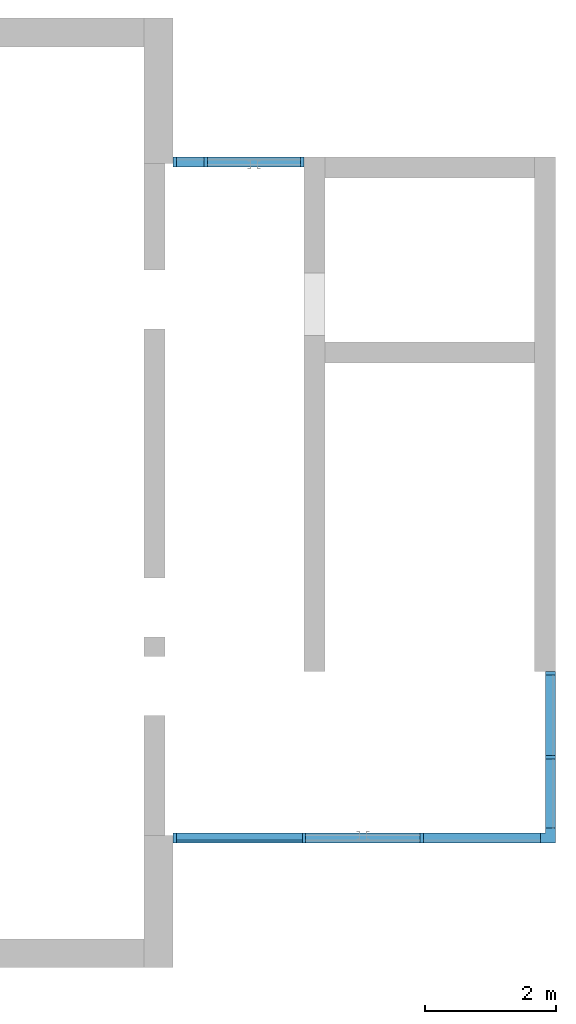
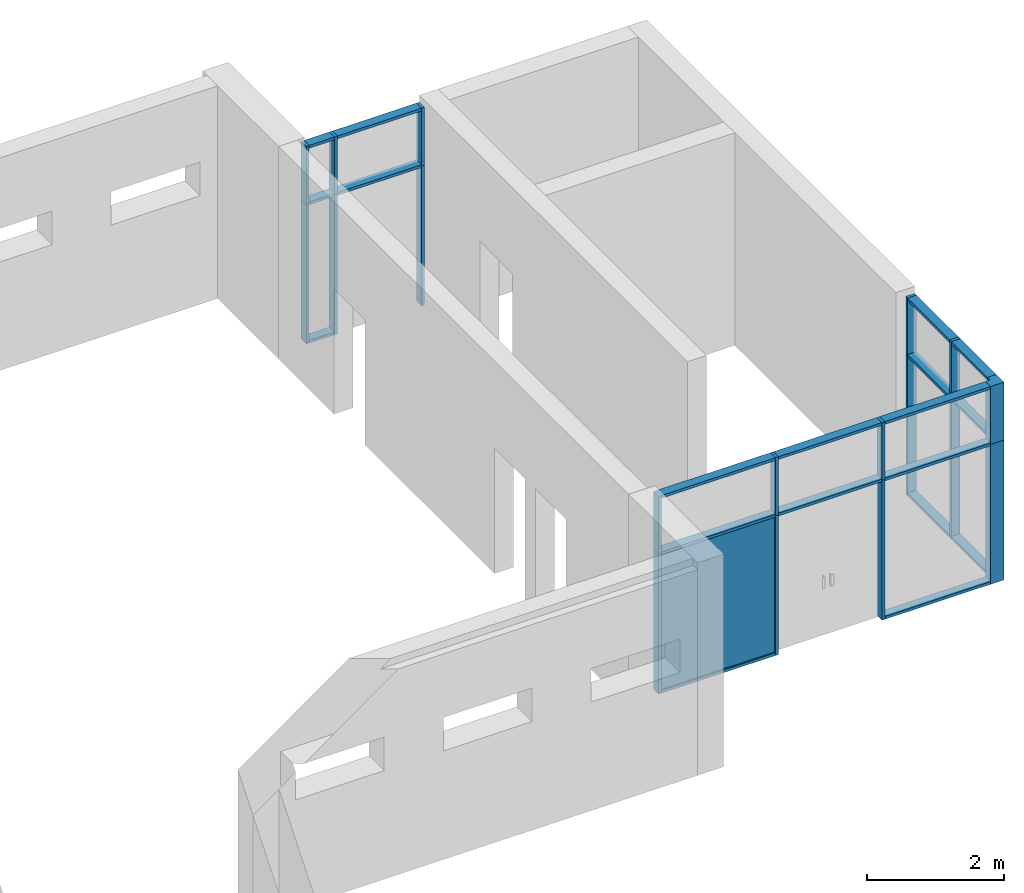
# One storey, part 1 of 4: 37 members, 1 plate, 3 elements without a shape of their own.
"""IFC2X3 building model written with IfcOpenShell, lengths in millimetres."""

from ifc_helpers import new_model, entity, si_unit, converted_unit, derived_unit, direction, frame, frame_2d, origin, origin_2d_with_axis, place, context, subcontext, project, spatial, polyline, rectangle, outline, extrude, source, transform, mapped, material, layer, layer_set, layer_usage, type_object, type_shapes, element, aggregate, save


model = new_model("IFC2X3")

# Units and contexts
model_context = context("Model", 3, precision=0.01, world=origin(), true_north=direction((6.12303176911189e-17, 1.0)))
body_context = subcontext(model_context, "Body", "Model", "MODEL_VIEW")
ifc_project = project(units=[si_unit("LENGTHUNIT", "METRE", prefix="MILLI"), si_unit("AREAUNIT", "SQUARE_METRE"), si_unit("VOLUMEUNIT", "CUBIC_METRE"), converted_unit("PLANEANGLEUNIT", "DEGREE", entity("IfcRatioMeasure", 0.0174532925199433), si_unit("PLANEANGLEUNIT", "RADIAN"), dimensions=[0, 0, 0, 0, 0, 0, 0]), si_unit("MASSUNIT", "GRAM", prefix="KILO"), derived_unit("MASSDENSITYUNIT", [(si_unit("MASSUNIT", "GRAM", prefix="KILO"), 1), (si_unit("LENGTHUNIT", "METRE"), -3)]), si_unit("TIMEUNIT", "SECOND"), si_unit("FREQUENCYUNIT", "HERTZ"), si_unit("THERMODYNAMICTEMPERATUREUNIT", "DEGREE_CELSIUS"), derived_unit("THERMALTRANSMITTANCEUNIT", [(si_unit("MASSUNIT", "GRAM", prefix="KILO"), 1), (si_unit("THERMODYNAMICTEMPERATUREUNIT", "KELVIN"), -1), (si_unit("TIMEUNIT", "SECOND"), -3)]), derived_unit("VOLUMETRICFLOWRATEUNIT", [(si_unit("LENGTHUNIT", "METRE"), 3), (si_unit("TIMEUNIT", "SECOND"), -1)]), si_unit("ELECTRICCURRENTUNIT", "AMPERE"), si_unit("ELECTRICVOLTAGEUNIT", "VOLT"), si_unit("POWERUNIT", "WATT"), si_unit("FORCEUNIT", "NEWTON", prefix="KILO"), si_unit("ILLUMINANCEUNIT", "LUX"), si_unit("LUMINOUSFLUXUNIT", "LUMEN"), si_unit("LUMINOUSINTENSITYUNIT", "CANDELA"), derived_unit("USERDEFINED", [(si_unit("MASSUNIT", "GRAM", prefix="KILO"), -1), (si_unit("LENGTHUNIT", "METRE"), -2), (si_unit("TIMEUNIT", "SECOND"), 3), (si_unit("LUMINOUSFLUXUNIT", "LUMEN"), 1)]), derived_unit("LINEARVELOCITYUNIT", [(si_unit("LENGTHUNIT", "METRE"), 1), (si_unit("TIMEUNIT", "SECOND"), -1)]), si_unit("PRESSUREUNIT", "PASCAL"), derived_unit("USERDEFINED", [(si_unit("LENGTHUNIT", "METRE"), -2), (si_unit("MASSUNIT", "GRAM", prefix="KILO"), 1), (si_unit("TIMEUNIT", "SECOND"), -2)])], contexts=[model_context])

# Site, building, storey
site_placement = place(None, origin())
site = spatial("IfcSite", under=ifc_project, at=site_placement, CompositionType="ELEMENT")
building_placement = place(site_placement, origin())
building = spatial("IfcBuilding", under=site, at=building_placement, CompositionType="ELEMENT")
storey_placement = place(building_placement, origin())
storey = spatial("IfcBuildingStorey", under=building, at=storey_placement, Name="00 Ground level", CompositionType="ELEMENT", Elevation=0.0)

# Curtain wall, member
curtain_wall_type = type_object("IfcCurtainWallType", Name="Curtain Wall", PredefinedType="NOTDEFINED")
curtain_wall_1_placement = place(storey_placement, origin())
curtain_wall_1 = element("IfcCurtainWall", 1, at=curtain_wall_1_placement, inside=storey, type_object=curtain_wall_type, Name="Curtain Wall", ObjectType="Curtain Wall")
ifc_material_1 = material(Name="Aluminium")
member_type_1 = type_object("IfcMemberType", Name="50 x 150mm", PredefinedType="MEMBER")
shared_shape_1 = source(origin(), body_context, "Body", "SweptSolid", [
    extrude(rectangle(XDim=150.0, YDim=50.0, at=origin_2d_with_axis()), frame((-25.0, 0.0, -1035.0), z_axis=(0.0, 0.0, 1.0), x_axis=(0.0, -1.0, 0.0)), (0.0, 0.0, 1.0), 1035.0),
])
type_shapes(member_type_1, [shared_shape_1])
member_1_placement = place(storey_placement, frame((28943.4900708518, -74100.8241905963, 3535.0), z_axis=(0.0, 0.0, 1.0), x_axis=(-1.0, 0.0, 0.0)))
member_1 = element("IfcMember", 2, at=member_1_placement, type_object=member_type_1, material=ifc_material_1, Name="Rectangular Mullion:50 x 150mm", ObjectType="Rectangular Mullion:50 x 150mm", context=body_context, shape_type="MappedRepresentation", body=[
    mapped(shared_shape_1, transform((0.0, 0.0, 0.0), scale=1.0)),
])

curtain_wall_2_placement = place(storey_placement, origin())
curtain_wall_2 = element("IfcCurtainWall", 3, at=curtain_wall_2_placement, inside=storey, type_object=curtain_wall_type, Name="Curtain Wall", ObjectType="Curtain Wall")
member_2_placement = place(storey_placement, frame((30943.4900708518, -63780.8241905964, 3535.0)))
member_2 = element("IfcMember", 4, at=member_2_placement, type_object=member_type_1, material=ifc_material_1, Name="Rectangular Mullion:50 x 150mm", ObjectType="Rectangular Mullion:50 x 150mm", context=body_context, shape_type="MappedRepresentation", body=[
    mapped(shared_shape_1, transform((0.0, 0.0, 0.0), scale=1.0)),
])

# Member
member_type_2 = type_object("IfcMemberType", Name="50 x 150mm", PredefinedType="MEMBER")
shared_shape_2 = source(origin(), body_context, "Body", "SweptSolid", [
    extrude(rectangle(XDim=150.0, YDim=50.0, at=origin_2d_with_axis()), frame((-25.0, 0.0, -1790.0), z_axis=(0.0, 0.0, 1.0), x_axis=(0.0, -1.0, 0.0)), (0.0, 0.0, 1.0), 1790.00000000007),
])
type_shapes(member_type_2, [shared_shape_2])
member_3_placement = place(storey_placement, frame((34558.4900708518, -74100.8241905963, 3535.0), z_axis=(1.0, 0.0, 0.0), x_axis=(0.0, 0.0, 1.0)))
member_3 = element("IfcMember", 5, at=member_3_placement, type_object=member_type_2, material=ifc_material_1, Name="Rectangular Mullion:50 x 150mm", ObjectType="Rectangular Mullion:50 x 150mm", context=body_context, shape_type="MappedRepresentation", body=[
    mapped(shared_shape_2, transform((0.0, 0.0, 0.0), scale=1.0)),
])

member_type_3 = type_object("IfcMemberType", Name="50 x 150mm", PredefinedType="MEMBER")
shared_shape_3 = source(origin(), body_context, "Body", "SweptSolid", [
    extrude(rectangle(XDim=150.0, YDim=50.0, at=origin_2d_with_axis()), frame((-25.0, 0.0, -1925.0), z_axis=(0.0, 0.0, 1.0), x_axis=(0.0, -1.0, 0.0)), (0.0, 0.0, 1.0), 1924.99999999991),
])
type_shapes(member_type_3, [shared_shape_3])
member_4_placement = place(storey_placement, frame((28993.4900708518, -74100.8241905963, 0.0), z_axis=(-1.0, 0.0, 0.0), x_axis=(0.0, 0.0, -1.0)))
member_4 = element("IfcMember", 6, at=member_4_placement, type_object=member_type_3, material=ifc_material_1, Name="Rectangular Mullion:50 x 150mm", ObjectType="Rectangular Mullion:50 x 150mm", context=body_context, shape_type="MappedRepresentation", body=[
    mapped(shared_shape_3, transform((0.0, 0.0, 0.0), scale=1.0)),
])

member_type_4 = type_object("IfcMemberType", Name="50 x 150mm", PredefinedType="MEMBER")
shared_shape_4 = source(origin(), body_context, "Body", "SweptSolid", [
    extrude(rectangle(XDim=150.0, YDim=50.0, at=origin_2d_with_axis()), frame((0.0, 0.0, -2500.0), z_axis=(0.0, 0.0, 1.0), x_axis=(0.0, -1.0, 0.0)), (0.0, 0.0, 1.0), 2500.0),
])
type_shapes(member_type_4, [shared_shape_4])
member_5_placement = place(storey_placement, frame((30943.4900708517, -74100.8241905963, 0.0), z_axis=(0.0, 0.0, -1.0), x_axis=(1.0, 0.0, 0.0)))
member_5 = element("IfcMember", 7, at=member_5_placement, type_object=member_type_4, material=ifc_material_1, Name="Rectangular Mullion:50 x 150mm", ObjectType="Rectangular Mullion:50 x 150mm", context=body_context, shape_type="MappedRepresentation", body=[
    mapped(shared_shape_4, transform((0.0, 0.0, 0.0), scale=1.0)),
])

member_6_placement = place(storey_placement, frame((32743.4900708517, -74100.8241905963, 0.0), z_axis=(0.0, 0.0, -1.0), x_axis=(1.0, 0.0, 0.0)))
member_6 = element("IfcMember", 8, at=member_6_placement, type_object=member_type_4, material=ifc_material_1, Name="Rectangular Mullion:50 x 150mm", ObjectType="Rectangular Mullion:50 x 150mm", context=body_context, shape_type="MappedRepresentation", body=[
    mapped(shared_shape_4, transform((0.0, 0.0, 0.0), scale=1.0)),
])

# Curtain wall, member
curtain_wall_3_placement = place(storey_placement, origin())
curtain_wall_3 = element("IfcCurtainWall", 9, at=curtain_wall_3_placement, inside=storey, type_object=curtain_wall_type, Name="Curtain Wall", ObjectType="Curtain Wall")
member_7_placement = place(storey_placement, frame((34708.4900708518, -72868.3241905963, 0.0), z_axis=(0.0, 0.0, -1.0), x_axis=(0.0, 1.0, 0.0)))
member_7 = element("IfcMember", 10, at=member_7_placement, type_object=member_type_4, material=ifc_material_1, Name="Rectangular Mullion:50 x 150mm", ObjectType="Rectangular Mullion:50 x 150mm", context=body_context, shape_type="MappedRepresentation", body=[
    mapped(shared_shape_4, transform((0.0, 0.0, 0.0), scale=1.0)),
])

# Member
member_8_placement = place(storey_placement, frame((29443.4900708518, -63780.8241905964, 0.0), z_axis=(0.0, 0.0, -1.0), x_axis=(-1.0, 0.0, 0.0)))
member_8 = element("IfcMember", 11, at=member_8_placement, type_object=member_type_4, material=ifc_material_1, Name="Rectangular Mullion:50 x 150mm", ObjectType="Rectangular Mullion:50 x 150mm", context=body_context, shape_type="MappedRepresentation", body=[
    mapped(shared_shape_4, transform((0.0, 0.0, 0.0), scale=1.0)),
])

member_type_5 = type_object("IfcMemberType", Name="50 x 150mm", PredefinedType="MEMBER")
shared_shape_5 = source(origin(), body_context, "Body", "SweptSolid", [
    extrude(rectangle(XDim=150.0, YDim=50.0, at=origin_2d_with_axis()), frame((0.0, 0.0, -1925.0), z_axis=(0.0, 0.0, 1.0), x_axis=(0.0, -1.0, 0.0)), (0.0, 0.0, 1.0), 1924.99999999991),
])
type_shapes(member_type_5, [shared_shape_5])
member_9_placement = place(storey_placement, frame((30918.4900708517, -74100.8241905963, 2500.0), z_axis=(1.0, 0.0, 0.0), x_axis=(0.0, 0.0, 1.0)))
member_9 = element("IfcMember", 12, at=member_9_placement, type_object=member_type_5, material=ifc_material_1, Name="Rectangular Mullion:50 x 150mm", ObjectType="Rectangular Mullion:50 x 150mm", context=body_context, shape_type="MappedRepresentation", body=[
    mapped(shared_shape_5, transform((0.0, 0.0, 0.0), scale=1.0)),
])

member_type_6 = type_object("IfcMemberType", Name="50 x 150mm", PredefinedType="MEMBER")
shared_shape_6 = source(origin(), body_context, "Body", "SweptSolid", [
    extrude(rectangle(XDim=150.0, YDim=50.0, at=origin_2d_with_axis()), frame((0.0, 0.0, -1750.0), z_axis=(0.0, 0.0, 1.0), x_axis=(0.0, -1.0, 0.0)), (0.0, 0.0, 1.0), 1750.0),
])
type_shapes(member_type_6, [shared_shape_6])
member_10_placement = place(storey_placement, frame((32718.4900708517, -74100.8241905963, 2500.0), z_axis=(1.0, 0.0, 0.0), x_axis=(0.0, 0.0, 1.0)))
member_10 = element("IfcMember", 13, at=member_10_placement, type_object=member_type_6, material=ifc_material_1, Name="Rectangular Mullion:50 x 150mm", ObjectType="Rectangular Mullion:50 x 150mm", context=body_context, shape_type="MappedRepresentation", body=[
    mapped(shared_shape_6, transform((0.0, 0.0, 0.0), scale=1.0)),
])

member_type_7 = type_object("IfcMemberType", Name="50 x 150mm", PredefinedType="MEMBER")
shared_shape_7 = source(origin(), body_context, "Body", "SweptSolid", [
    extrude(rectangle(XDim=150.0, YDim=50.0, at=origin_2d_with_axis()), frame((0.0, 0.0, -1790.0), z_axis=(0.0, 0.0, 1.0), x_axis=(0.0, -1.0, 0.0)), (0.0, 0.0, 1.0), 1790.00000000007),
])
type_shapes(member_type_7, [shared_shape_7])
member_11_placement = place(storey_placement, frame((34558.4900708518, -74100.8241905963, 2500.0), z_axis=(1.0, 0.0, 0.0), x_axis=(0.0, 0.0, 1.0)))
member_11 = element("IfcMember", 14, at=member_11_placement, type_object=member_type_7, material=ifc_material_1, Name="Rectangular Mullion:50 x 150mm", ObjectType="Rectangular Mullion:50 x 150mm", context=body_context, shape_type="MappedRepresentation", body=[
    mapped(shared_shape_7, transform((0.0, 0.0, 0.0), scale=1.0)),
])

member_type_8 = type_object("IfcMemberType", Name="50 x 150mm", PredefinedType="MEMBER")
shared_shape_8 = source(origin(), body_context, "Body", "SweptSolid", [
    extrude(rectangle(XDim=150.0, YDim=50.0, at=origin_2d_with_axis()), frame((-25.0, 0.0, -1790.0), z_axis=(0.0, 0.0, 1.0), x_axis=(0.0, -1.0, 0.0)), (0.0, 0.0, 1.0), 1790.00000000007),
])
type_shapes(member_type_8, [shared_shape_8])
member_12_placement = place(storey_placement, frame((32768.4900708517, -74100.8241905963, 0.0), z_axis=(-1.0, 0.0, 0.0), x_axis=(0.0, 0.0, -1.0)))
member_12 = element("IfcMember", 15, at=member_12_placement, type_object=member_type_8, material=ifc_material_1, Name="Rectangular Mullion:50 x 150mm", ObjectType="Rectangular Mullion:50 x 150mm", context=body_context, shape_type="MappedRepresentation", body=[
    mapped(shared_shape_8, transform((0.0, 0.0, 0.0), scale=1.0)),
])

member_type_9 = type_object("IfcMemberType", Name="50 x 150mm", PredefinedType="MEMBER")
shared_shape_9 = source(origin(), body_context, "Body", "SweptSolid", [
    extrude(rectangle(XDim=150.0, YDim=50.0, at=origin_2d_with_axis()), frame((-25.0, 0.0, -1925.0), z_axis=(0.0, 0.0, 1.0), x_axis=(0.0, -1.0, 0.0)), (0.0, 0.0, 1.0), 1924.99999999992),
])
type_shapes(member_type_9, [shared_shape_9])
member_13_placement = place(storey_placement, frame((30918.4900708517, -74100.8241905963, 3535.0), z_axis=(1.0, 0.0, 0.0), x_axis=(0.0, 0.0, 1.0)))
member_13 = element("IfcMember", 16, at=member_13_placement, type_object=member_type_9, material=ifc_material_1, Name="Rectangular Mullion:50 x 150mm", ObjectType="Rectangular Mullion:50 x 150mm", context=body_context, shape_type="MappedRepresentation", body=[
    mapped(shared_shape_9, transform((0.0, 0.0, 0.0), scale=1.0)),
])

member_type_10 = type_object("IfcMemberType", Name="50 x 150mm", PredefinedType="MEMBER")
shared_shape_10 = source(origin(), body_context, "Body", "SweptSolid", [
    extrude(rectangle(XDim=150.0, YDim=50.0, at=origin_2d_with_axis()), frame((-25.0, 0.0, -1750.0), z_axis=(0.0, 0.0, 1.0), x_axis=(0.0, -1.0, 0.0)), (0.0, 0.0, 1.0), 1750.0),
])
type_shapes(member_type_10, [shared_shape_10])
member_14_placement = place(storey_placement, frame((32718.4900708517, -74100.8241905963, 3535.0), z_axis=(1.0, 0.0, 0.0), x_axis=(0.0, 0.0, 1.0)))
member_14 = element("IfcMember", 17, at=member_14_placement, type_object=member_type_10, material=ifc_material_1, Name="Rectangular Mullion:50 x 150mm", ObjectType="Rectangular Mullion:50 x 150mm", context=body_context, shape_type="MappedRepresentation", body=[
    mapped(shared_shape_10, transform((0.0, 0.0, 0.0), scale=1.0)),
])

member_type_11 = type_object("IfcMemberType", Name="50 x 150mm", PredefinedType="MEMBER")
shared_shape_11 = source(origin(), body_context, "Body", "SweptSolid", [
    extrude(rectangle(XDim=150.0, YDim=50.0, at=origin_2d_with_axis()), frame((-25.0, 0.0, -2500.0), z_axis=(0.0, 0.0, 1.0), x_axis=(0.0, -1.0, 0.0)), (0.0, 0.0, 1.0), 2500.0),
])
type_shapes(member_type_11, [shared_shape_11])
member_15_placement = place(storey_placement, frame((28943.4900708518, -74100.8241905963, 2500.0), z_axis=(0.0, 0.0, 1.0), x_axis=(-1.0, 0.0, 0.0)))
member_15 = element("IfcMember", 18, at=member_15_placement, type_object=member_type_11, material=ifc_material_1, Name="Rectangular Mullion:50 x 150mm", ObjectType="Rectangular Mullion:50 x 150mm", context=body_context, shape_type="MappedRepresentation", body=[
    mapped(shared_shape_11, transform((0.0, 0.0, 0.0), scale=1.0)),
])

member_type_12 = type_object("IfcMemberType", Name="50 x 150mm", PredefinedType="MEMBER")
shared_shape_12 = source(origin(), body_context, "Body", "SweptSolid", [
    extrude(rectangle(XDim=150.0, YDim=50.0, at=origin_2d_with_axis()), frame((0.0, 0.0, -1035.0), z_axis=(0.0, 0.0, 1.0), x_axis=(0.0, -1.0, 0.0)), (0.0, 0.0, 1.0), 1035.0),
])
type_shapes(member_type_12, [shared_shape_12])
member_16_placement = place(storey_placement, frame((30943.4900708517, -74100.8241905963, 2500.0), z_axis=(0.0, 0.0, -1.0), x_axis=(1.0, 0.0, 0.0)))
member_16 = element("IfcMember", 19, at=member_16_placement, type_object=member_type_12, material=ifc_material_1, Name="Rectangular Mullion:50 x 150mm", ObjectType="Rectangular Mullion:50 x 150mm", context=body_context, shape_type="MappedRepresentation", body=[
    mapped(shared_shape_12, transform((0.0, 0.0, 0.0), scale=1.0)),
])

member_17_placement = place(storey_placement, frame((32743.4900708517, -74100.8241905963, 2500.0), z_axis=(0.0, 0.0, -1.0), x_axis=(1.0, 0.0, 0.0)))
member_17 = element("IfcMember", 20, at=member_17_placement, type_object=member_type_12, material=ifc_material_1, Name="Rectangular Mullion:50 x 150mm", ObjectType="Rectangular Mullion:50 x 150mm", context=body_context, shape_type="MappedRepresentation", body=[
    mapped(shared_shape_12, transform((0.0, 0.0, 0.0), scale=1.0)),
])

member_18_placement = place(storey_placement, frame((34708.4900708518, -72868.3241905963, 2500.0), z_axis=(0.0, 0.0, -1.0), x_axis=(0.0, 1.0, 0.0)))
member_18 = element("IfcMember", 21, at=member_18_placement, type_object=member_type_12, material=ifc_material_1, Name="Rectangular Mullion:50 x 150mm", ObjectType="Rectangular Mullion:50 x 150mm", context=body_context, shape_type="MappedRepresentation", body=[
    mapped(shared_shape_12, transform((0.0, 0.0, 0.0), scale=1.0)),
])

member_19_placement = place(storey_placement, frame((29443.4900708518, -63780.8241905964, 2500.0), z_axis=(0.0, 0.0, -1.0), x_axis=(-1.0, 0.0, 0.0)))
member_19 = element("IfcMember", 22, at=member_19_placement, type_object=member_type_12, material=ifc_material_1, Name="Rectangular Mullion:50 x 150mm", ObjectType="Rectangular Mullion:50 x 150mm", context=body_context, shape_type="MappedRepresentation", body=[
    mapped(shared_shape_12, transform((0.0, 0.0, 0.0), scale=1.0)),
])

member_type_13 = type_object("IfcMemberType", Name="50 x 150mm", PredefinedType="MEMBER")
shared_shape_13 = source(origin(), body_context, "Body", "SweptSolid", [
    extrude(rectangle(XDim=150.0, YDim=50.0, at=origin_2d_with_axis()), frame((-25.0, 0.0, -1232.49999999999), z_axis=(0.0, 0.0, 1.0), x_axis=(0.0, -1.0, 0.0)), (0.0, 0.0, 1.0), 1232.49999999999),
])
type_shapes(member_type_13, [shared_shape_13])
member_20_placement = place(storey_placement, frame((34708.4900708518, -71610.8241905963, 3535.0), z_axis=(0.0, 1.0, 0.0), x_axis=(0.0, 0.0, 1.0)))
member_20 = element("IfcMember", 23, at=member_20_placement, type_object=member_type_13, material=ifc_material_1, Name="Rectangular Mullion:50 x 150mm", ObjectType="Rectangular Mullion:50 x 150mm", context=body_context, shape_type="MappedRepresentation", body=[
    mapped(shared_shape_13, transform((0.0, 0.0, 0.0), scale=1.0)),
])

member_type_14 = type_object("IfcMemberType", Name="50 x 150mm", PredefinedType="MEMBER")
shared_shape_14 = source(origin(), body_context, "Body", "SweptSolid", [
    extrude(rectangle(XDim=150.0, YDim=50.0, at=origin_2d_with_axis()), frame((-25.0, 0.0, -2500.0), z_axis=(0.0, 0.0, 1.0), x_axis=(0.0, -1.0, 0.0)), (0.0, 0.0, 1.0), 2500.0),
])
type_shapes(member_type_14, [shared_shape_14])
member_21_placement = place(storey_placement, frame((34708.4900708518, -71560.8241905963, 0.0), z_axis=(0.0, 0.0, -1.0), x_axis=(0.0, 1.0, 0.0)))
member_21 = element("IfcMember", 24, at=member_21_placement, type_object=member_type_14, material=ifc_material_1, Name="Rectangular Mullion:50 x 150mm", ObjectType="Rectangular Mullion:50 x 150mm", context=body_context, shape_type="MappedRepresentation", body=[
    mapped(shared_shape_14, transform((0.0, 0.0, 0.0), scale=1.0)),
])

member_22_placement = place(storey_placement, frame((28943.4900708518, -63780.8241905964, 0.0), z_axis=(0.0, 0.0, -1.0), x_axis=(-1.0, 0.0, 0.0)))
member_22 = element("IfcMember", 25, at=member_22_placement, type_object=member_type_14, material=ifc_material_1, Name="Rectangular Mullion:50 x 150mm", ObjectType="Rectangular Mullion:50 x 150mm", context=body_context, shape_type="MappedRepresentation", body=[
    mapped(shared_shape_14, transform((0.0, 0.0, 0.0), scale=1.0)),
])

member_type_15 = type_object("IfcMemberType", Name="50 x 150mm", PredefinedType="MEMBER")
shared_shape_15 = source(origin(), body_context, "Body", "SweptSolid", [
    extrude(rectangle(XDim=150.0, YDim=50.0, at=origin_2d_with_axis()), frame((-25.0, 0.0, -1057.5), z_axis=(0.0, 0.0, 1.0), x_axis=(0.0, -1.0, 0.0)), (0.0, 0.0, 1.0), 1057.5),
])
type_shapes(member_type_15, [shared_shape_15])
member_23_placement = place(storey_placement, frame((34708.4900708518, -73950.8241905963, 0.0), z_axis=(0.0, -1.0, 0.0), x_axis=(0.0, 0.0, -1.0)))
member_23 = element("IfcMember", 26, at=member_23_placement, type_object=member_type_15, material=ifc_material_1, Name="Rectangular Mullion:50 x 150mm", ObjectType="Rectangular Mullion:50 x 150mm", context=body_context, shape_type="MappedRepresentation", body=[
    mapped(shared_shape_15, transform((0.0, 0.0, 0.0), scale=1.0)),
])

member_type_16 = type_object("IfcMemberType", Name="50 x 150mm", PredefinedType="MEMBER")
shared_shape_16 = source(origin(), body_context, "Body", "SweptSolid", [
    extrude(rectangle(XDim=150.0, YDim=50.0, at=origin_2d_with_axis()), frame((0.0, 0.0, -1057.49999999999), z_axis=(0.0, 0.0, 1.0), x_axis=(0.0, -1.0, 0.0)), (0.0, 0.0, 1.0), 1057.5),
])
type_shapes(member_type_16, [shared_shape_16])
member_24_placement = place(storey_placement, frame((34708.4900708518, -72893.3241905963, 2500.0), z_axis=(0.0, 1.0, 0.0), x_axis=(0.0, 0.0, 1.0)))
member_24 = element("IfcMember", 27, at=member_24_placement, type_object=member_type_16, material=ifc_material_1, Name="Rectangular Mullion:50 x 150mm", ObjectType="Rectangular Mullion:50 x 150mm", context=body_context, shape_type="MappedRepresentation", body=[
    mapped(shared_shape_16, transform((0.0, 0.0, 0.0), scale=1.0)),
])

member_type_17 = type_object("IfcMemberType", Name="50 x 150mm", PredefinedType="MEMBER")
shared_shape_17 = source(origin(), body_context, "Body", "SweptSolid", [
    extrude(rectangle(XDim=150.0, YDim=50.0, at=origin_2d_with_axis()), frame((0.0, 0.0, -1232.49999999999), z_axis=(0.0, 0.0, 1.0), x_axis=(0.0, -1.0, 0.0)), (0.0, 0.0, 1.0), 1232.49999999999),
])
type_shapes(member_type_17, [shared_shape_17])
member_25_placement = place(storey_placement, frame((34708.4900708518, -71610.8241905963, 2500.0), z_axis=(0.0, 1.0, 0.0), x_axis=(0.0, 0.0, 1.0)))
member_25 = element("IfcMember", 28, at=member_25_placement, type_object=member_type_17, material=ifc_material_1, Name="Rectangular Mullion:50 x 150mm", ObjectType="Rectangular Mullion:50 x 150mm", context=body_context, shape_type="MappedRepresentation", body=[
    mapped(shared_shape_17, transform((0.0, 0.0, 0.0), scale=1.0)),
])

member_type_18 = type_object("IfcMemberType", Name="50 x 150mm", PredefinedType="MEMBER")
shared_shape_18 = source(origin(), body_context, "Body", "SweptSolid", [
    extrude(rectangle(XDim=150.0, YDim=50.0, at=origin_2d_with_axis()), frame((-25.0, 0.0, -1232.49999999999), z_axis=(0.0, 0.0, 1.0), x_axis=(0.0, -1.0, 0.0)), (0.0, 0.0, 1.0), 1232.49999999999),
])
type_shapes(member_type_18, [shared_shape_18])
member_26_placement = place(storey_placement, frame((34708.4900708518, -72843.3241905963, 0.0), z_axis=(0.0, -1.0, 0.0), x_axis=(0.0, 0.0, -1.0)))
member_26 = element("IfcMember", 29, at=member_26_placement, type_object=member_type_18, material=ifc_material_1, Name="Rectangular Mullion:50 x 150mm", ObjectType="Rectangular Mullion:50 x 150mm", context=body_context, shape_type="MappedRepresentation", body=[
    mapped(shared_shape_18, transform((0.0, 0.0, 0.0), scale=1.0)),
])

member_type_19 = type_object("IfcMemberType", Name="50 x 150mm", PredefinedType="MEMBER")
shared_shape_19 = source(origin(), body_context, "Body", "SweptSolid", [
    extrude(rectangle(XDim=150.0, YDim=50.0, at=origin_2d_with_axis()), frame((-25.0, 0.0, -1035.0), z_axis=(0.0, 0.0, 1.0), x_axis=(0.0, -1.0, 0.0)), (0.0, 0.0, 1.0), 1035.0),
])
type_shapes(member_type_19, [shared_shape_19])
member_27_placement = place(storey_placement, frame((34708.4900708518, -71560.8241905963, 2500.0), z_axis=(0.0, 0.0, -1.0), x_axis=(0.0, 1.0, 0.0)))
member_27 = element("IfcMember", 30, at=member_27_placement, type_object=member_type_19, material=ifc_material_1, Name="Rectangular Mullion:50 x 150mm", ObjectType="Rectangular Mullion:50 x 150mm", context=body_context, shape_type="MappedRepresentation", body=[
    mapped(shared_shape_19, transform((0.0, 0.0, 0.0), scale=1.0)),
])

member_28_placement = place(storey_placement, frame((28943.4900708518, -63780.8241905964, 2500.0), z_axis=(0.0, 0.0, -1.0), x_axis=(-1.0, 0.0, 0.0)))
member_28 = element("IfcMember", 31, at=member_28_placement, type_object=member_type_19, material=ifc_material_1, Name="Rectangular Mullion:50 x 150mm", ObjectType="Rectangular Mullion:50 x 150mm", context=body_context, shape_type="MappedRepresentation", body=[
    mapped(shared_shape_19, transform((0.0, 0.0, 0.0), scale=1.0)),
])

member_type_20 = type_object("IfcMemberType", Name="50 x 150mm", PredefinedType="MEMBER")
shared_shape_20 = source(origin(), body_context, "Body", "SweptSolid", [
    extrude(rectangle(XDim=150.0, YDim=50.0, at=origin_2d_with_axis()), frame((-25.0, 0.0, -1057.49999999999), z_axis=(0.0, 0.0, 1.0), x_axis=(0.0, -1.0, 0.0)), (0.0, 0.0, 1.0), 1057.5),
])
type_shapes(member_type_20, [shared_shape_20])
member_29_placement = place(storey_placement, frame((34708.4900708518, -72893.3241905963, 3535.0), z_axis=(0.0, 1.0, 0.0), x_axis=(0.0, 0.0, 1.0)))
member_29 = element("IfcMember", 32, at=member_29_placement, type_object=member_type_20, material=ifc_material_1, Name="Rectangular Mullion:50 x 150mm", ObjectType="Rectangular Mullion:50 x 150mm", context=body_context, shape_type="MappedRepresentation", body=[
    mapped(shared_shape_20, transform((0.0, 0.0, 0.0), scale=1.0)),
])

member_type_21 = type_object("IfcMemberType", Name="L Mullion 1", PredefinedType="MEMBER")
shared_shape_21 = source(origin(), body_context, "Body", "SweptSolid", [
    extrude(outline(polyline([(-125.0, -100.0), (25.0, -100.0), (25.0, -25.0), (100.0, -25.0), (100.0, 125.0), (-125.0, 125.0), (-125.0, -100.0)])), frame((-50.0, -50.0, -2500.0), z_axis=(0.0, 0.0, 1.0), x_axis=(0.0, -1.0, 0.0)), (0.0, 0.0, 1.0), 2500.0),
])
type_shapes(member_type_21, [shared_shape_21])
member_30_placement = place(storey_placement, frame((34708.4900708518, -74100.8241905963, 2500.0), z_axis=(0.0, 0.0, 1.0), x_axis=(0.0, -1.0, 0.0)))
member_30 = element("IfcMember", 33, at=member_30_placement, type_object=member_type_21, material=ifc_material_1, Name="L Corner Mullion:L Mullion 1", ObjectType="L Corner Mullion:L Mullion 1", context=body_context, shape_type="MappedRepresentation", body=[
    mapped(shared_shape_21, transform((0.0, 0.0, 0.0), scale=1.0)),
])

member_type_22 = type_object("IfcMemberType", Name="L Mullion 1", PredefinedType="MEMBER")
shared_shape_22 = source(origin(), body_context, "Body", "SweptSolid", [
    extrude(outline(polyline([(-125.0, -100.0), (25.0, -100.0), (25.0, -25.0), (100.0, -25.0), (100.0, 125.0), (-125.0, 125.0), (-125.0, -100.0)])), frame((-50.0, -50.0, -1035.0), z_axis=(0.0, 0.0, 1.0), x_axis=(0.0, -1.0, 0.0)), (0.0, 0.0, 1.0), 1035.0),
])
type_shapes(member_type_22, [shared_shape_22])
member_31_placement = place(storey_placement, frame((34708.4900708518, -74100.8241905963, 3535.0), z_axis=(0.0, 0.0, 1.0), x_axis=(0.0, -1.0, 0.0)))
member_31 = element("IfcMember", 34, at=member_31_placement, type_object=member_type_22, material=ifc_material_1, Name="L Corner Mullion:L Mullion 1", ObjectType="L Corner Mullion:L Mullion 1", context=body_context, shape_type="MappedRepresentation", body=[
    mapped(shared_shape_22, transform((0.0, 0.0, 0.0), scale=1.0)),
])

aggregate(curtain_wall_3, [member_20, member_21, member_23, member_24, member_25, member_7, member_26, member_27, member_29, member_18, member_30, member_31])

member_type_23 = type_object("IfcMemberType", Name="50 x 150mm", PredefinedType="MEMBER")
shared_shape_23 = source(origin(), body_context, "Body", "SweptSolid", [
    extrude(rectangle(XDim=150.0, YDim=50.0, at=origin_2d_with_axis()), frame((-25.0, 0.0, -425.0), z_axis=(0.0, 0.0, 1.0), x_axis=(0.0, -1.0, 0.0)), (0.0, 0.0, 1.0), 425.000000000016),
])
type_shapes(member_type_23, [shared_shape_23])
member_32_placement = place(storey_placement, frame((28993.4900708518, -63780.8241905964, 3535.0), z_axis=(-1.0, 0.0, 0.0), x_axis=(0.0, 0.0, 1.0)))
member_32 = element("IfcMember", 35, at=member_32_placement, type_object=member_type_23, material=ifc_material_1, Name="Rectangular Mullion:50 x 150mm", ObjectType="Rectangular Mullion:50 x 150mm", context=body_context, shape_type="MappedRepresentation", body=[
    mapped(shared_shape_23, transform((0.0, 0.0, 0.0), scale=1.0)),
])

member_type_24 = type_object("IfcMemberType", Name="50 x 150mm", PredefinedType="MEMBER")
shared_shape_24 = source(origin(), body_context, "Body", "SweptSolid", [
    extrude(rectangle(XDim=150.0, YDim=50.0, at=origin_2d_with_axis()), frame((0.0, 0.0, -1425.0), z_axis=(0.0, 0.0, 1.0), x_axis=(0.0, -1.0, 0.0)), (0.0, 0.0, 1.0), 1425.0),
])
type_shapes(member_type_24, [shared_shape_24])
member_33_placement = place(storey_placement, frame((29468.4900708518, -63780.8241905964, 2500.0), z_axis=(-1.0, 0.0, 0.0), x_axis=(0.0, 0.0, 1.0)))
member_33 = element("IfcMember", 36, at=member_33_placement, type_object=member_type_24, material=ifc_material_1, Name="Rectangular Mullion:50 x 150mm", ObjectType="Rectangular Mullion:50 x 150mm", context=body_context, shape_type="MappedRepresentation", body=[
    mapped(shared_shape_24, transform((0.0, 0.0, 0.0), scale=1.0)),
])

member_type_25 = type_object("IfcMemberType", Name="50 x 150mm", PredefinedType="MEMBER")
shared_shape_25 = source(origin(), body_context, "Body", "SweptSolid", [
    extrude(rectangle(XDim=150.0, YDim=50.0, at=origin_2d_with_axis()), frame((-25.0, 0.0, -2500.0), z_axis=(0.0, 0.0, 1.0), x_axis=(0.0, -1.0, 0.0)), (0.0, 0.0, 1.0), 2500.0),
])
type_shapes(member_type_25, [shared_shape_25])
member_34_placement = place(storey_placement, frame((30943.4900708518, -63780.8241905964, 2500.0)))
member_34 = element("IfcMember", 37, at=member_34_placement, type_object=member_type_25, material=ifc_material_1, Name="Rectangular Mullion:50 x 150mm", ObjectType="Rectangular Mullion:50 x 150mm", context=body_context, shape_type="MappedRepresentation", body=[
    mapped(shared_shape_25, transform((0.0, 0.0, 0.0), scale=1.0)),
])

member_type_26 = type_object("IfcMemberType", Name="50 x 150mm", PredefinedType="MEMBER")
shared_shape_26 = source(origin(), body_context, "Body", "SweptSolid", [
    extrude(rectangle(XDim=150.0, YDim=50.0, at=origin_2d_with_axis()), frame((-25.0, 0.0, -1425.0), z_axis=(0.0, 0.0, 1.0), x_axis=(0.0, -1.0, 0.0)), (0.0, 0.0, 1.0), 1425.0),
])
type_shapes(member_type_26, [shared_shape_26])
member_35_placement = place(storey_placement, frame((29468.4900708518, -63780.8241905964, 3535.0), z_axis=(-1.0, 0.0, 0.0), x_axis=(0.0, 0.0, 1.0)))
member_35 = element("IfcMember", 38, at=member_35_placement, type_object=member_type_26, material=ifc_material_1, Name="Rectangular Mullion:50 x 150mm", ObjectType="Rectangular Mullion:50 x 150mm", context=body_context, shape_type="MappedRepresentation", body=[
    mapped(shared_shape_26, transform((0.0, 0.0, 0.0), scale=1.0)),
])

member_type_27 = type_object("IfcMemberType", Name="50 x 150mm", PredefinedType="MEMBER")
shared_shape_27 = source(origin(), body_context, "Body", "SweptSolid", [
    extrude(rectangle(XDim=150.0, YDim=50.0, at=origin_2d_with_axis()), frame((0.0, 0.0, -425.0), z_axis=(0.0, 0.0, 1.0), x_axis=(0.0, -1.0, 0.0)), (0.0, 0.0, 1.0), 425.000000000017),
])
type_shapes(member_type_27, [shared_shape_27])
member_36_placement = place(storey_placement, frame((28993.4900708518, -63780.8241905964, 2500.0), z_axis=(-1.0, 0.0, 0.0), x_axis=(0.0, 0.0, 1.0)))
member_36 = element("IfcMember", 39, at=member_36_placement, type_object=member_type_27, material=ifc_material_1, Name="Rectangular Mullion:50 x 150mm", ObjectType="Rectangular Mullion:50 x 150mm", context=body_context, shape_type="MappedRepresentation", body=[
    mapped(shared_shape_27, transform((0.0, 0.0, 0.0), scale=1.0)),
])

member_type_28 = type_object("IfcMemberType", Name="50 x 150mm", PredefinedType="MEMBER")
shared_shape_28 = source(origin(), body_context, "Body", "SweptSolid", [
    extrude(rectangle(XDim=150.0, YDim=50.0, at=origin_2d_with_axis()), frame((-25.0, 0.0, -425.0), z_axis=(0.0, 0.0, 1.0), x_axis=(0.0, -1.0, 0.0)), (0.0, 0.0, 1.0), 425.000000000016),
])
type_shapes(member_type_28, [shared_shape_28])
member_37_placement = place(storey_placement, frame((29418.4900708518, -63780.8241905964, 0.0), z_axis=(1.0, 0.0, 0.0), x_axis=(0.0, 0.0, -1.0)))
member_37 = element("IfcMember", 40, at=member_37_placement, type_object=member_type_28, material=ifc_material_1, Name="Rectangular Mullion:50 x 150mm", ObjectType="Rectangular Mullion:50 x 150mm", context=body_context, shape_type="MappedRepresentation", body=[
    mapped(shared_shape_28, transform((0.0, 0.0, 0.0), scale=1.0)),
])

aggregate(curtain_wall_2, [member_2, member_32, member_22, member_33, member_28, member_34, member_35, member_36, member_19, member_8, member_37])

# Plate
ifc_material_2 = material()
ifc_layer = layer(ifc_material_2, 25.0)
ifc_layer_set = layer_set([ifc_layer], Name="System Panel:Glazed")
ifc_layer_usage = layer_usage(ifc_layer_set, "AXIS3", "POSITIVE", 0.121391076115486)
plate_type = type_object("IfcPlateType", Name="Glazed", PredefinedType="CURTAIN_PANEL", material=ifc_layer_set)
shared_shape_29 = source(origin(), body_context, "Body", "SweptSolid", [
    extrude(rectangle(XDim=25.0, YDim=1924.99999999991, at=frame_2d((2.66453525910038e-15, 0.0), x_axis=(1.0, 0.0))), frame((962.499999999957, 12.5, 0.0), z_axis=(0.0, 0.0, 1.0), x_axis=(0.0, 1.0, 0.0)), (0.0, 0.0, 1.0), 2425.0),
])
type_shapes(plate_type, [shared_shape_29])
plate_placement = place(curtain_wall_1_placement, frame((28993.4900708518, -74150.3241905963, 50.0)))
plate = element("IfcPlate", 41, at=plate_placement, type_object=plate_type, material=ifc_layer_usage, Name="System Panel:Glazed", ObjectType="System Panel:Glazed", context=body_context, shape_type="MappedRepresentation", body=[
    mapped(shared_shape_29, transform((0.0, 0.0, 0.0), scale=1.0)),
])

aggregate(curtain_wall_1, [plate, member_1, member_3, member_4, member_5, member_6, member_9, member_10, member_11, member_12, member_13, member_14, member_15, member_16, member_17])

save(model, "model.ifc")
